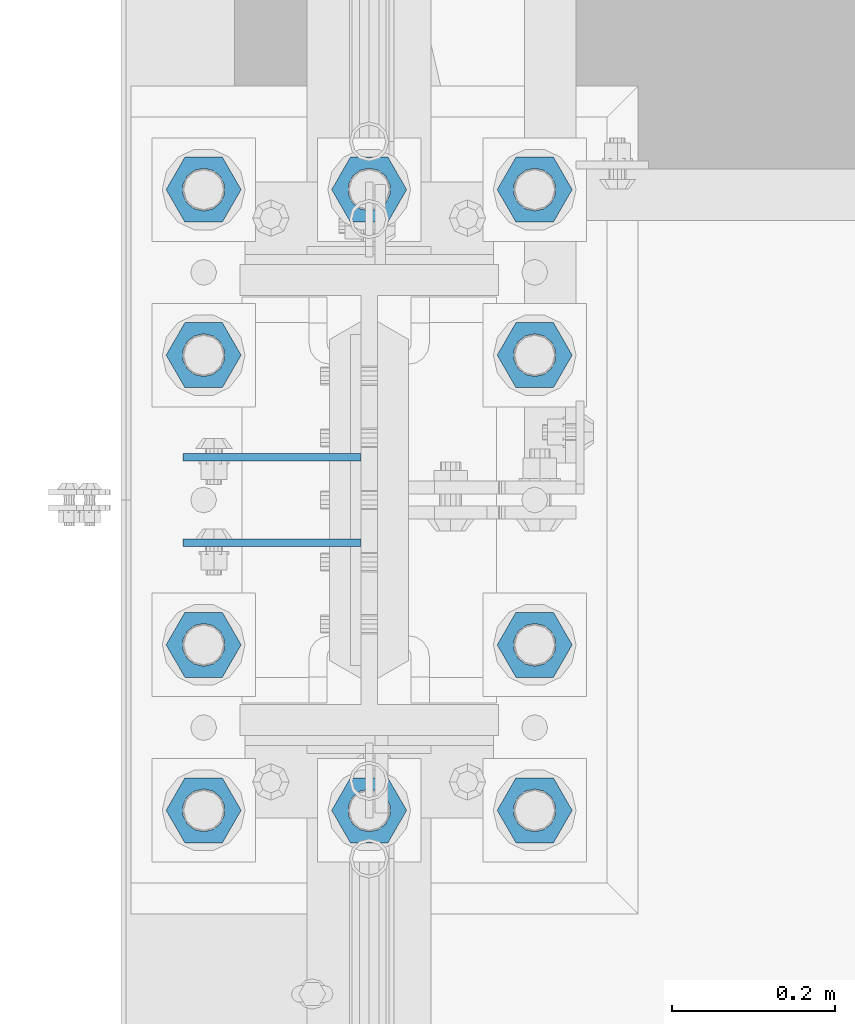
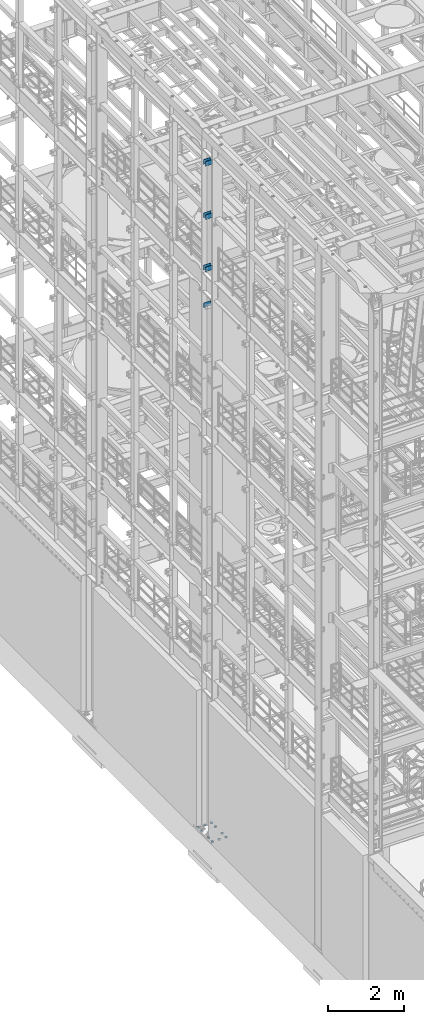
# One storey, part 1235 of 1876: 17 beams, 2 elements without a shape of their own.
"""IFC2X3 building model written with IfcOpenShell, lengths in millimetres."""

from ifc_helpers import new_model, si_unit, frame, origin_with_axes, place, context, subcontext, project, spatial, faceted_brep, material, type_object, element, aggregate, save


model = new_model("IFC2X3")

# Units and contexts
model_context = context("Model", 3, precision=1e-05, world=origin_with_axes())
body_context = subcontext(model_context, "Body", "Model", "MODEL_VIEW")
ifc_project = project(units=[si_unit("LENGTHUNIT", "METRE", prefix="MILLI"), si_unit("AREAUNIT", "SQUARE_METRE"), si_unit("VOLUMEUNIT", "CUBIC_METRE"), si_unit("MASSUNIT", "GRAM", prefix="KILO"), si_unit("TIMEUNIT", "SECOND"), si_unit("PLANEANGLEUNIT", "RADIAN"), si_unit("SOLIDANGLEUNIT", "STERADIAN"), si_unit("THERMODYNAMICTEMPERATUREUNIT", "DEGREE_CELSIUS"), si_unit("LUMINOUSINTENSITYUNIT", "LUMEN")], contexts=[model_context])

# Site, building, storey
site_placement = place(None, origin_with_axes())
site = spatial("IfcSite", under=ifc_project, at=site_placement, CompositionType="ELEMENT")
building_placement = place(site_placement, origin_with_axes())
building = spatial("IfcBuilding", under=site, at=building_placement, Name="Undefined", CompositionType="ELEMENT")
storey_placement = place(building_placement, origin_with_axes())
storey = spatial("IfcBuildingStorey", under=building, at=storey_placement, Name="Undefined", CompositionType="ELEMENT", Elevation=0.0)

# Assembly, beams
assembly_1_placement = place(storey_placement, origin_with_axes())
assembly_1 = element("IfcElementAssembly", 1, at=assembly_1_placement, inside=storey, Name="COLUMN", AssemblyPlace="NOTDEFINED", PredefinedType="RIGID_FRAME")
ifc_material_1 = material(Name="STEEL/A36")
beam_type_1 = type_object("IfcBeamType", PredefinedType="NOTDEFINED")
beam_1_placement = place(assembly_1_placement, frame((-10.31875, 1576.38750152589, 21678.9), z_axis=(0.0, 0.0, -1.0), x_axis=(-1.0, 0.0, 0.0)))
beam_1 = element("IfcBeam", 2, at=beam_1_placement, type_object=beam_type_1, material=ifc_material_1, Name="PLATE", context=body_context, shape_type="Brep", body=[
    faceted_brep([(0.0, 4.76249999999982, -76.1999999999998), (3.63797880709171e-12, 4.76249999999982, 76.1999969482422), (218.28125, 4.76250000000005, 76.2000000000007), (218.28125, 4.76250000000005, -76.2000000000007), (3.63797880709171e-12, -4.76249999999982, 76.1999969482422), (218.28125, -4.76250000000005, 76.2000000000007), (0.0, -4.76249999999982, -76.1999999999998), (218.28125, -4.76250000000005, -76.2000000000007)], [[[0, 1, 2, 3]], [[1, 4, 5, 2]], [[4, 6, 7, 5]], [[6, 0, 3, 7]], [[5, 7, 3, 2]], [[6, 4, 1, 0]]]),
])
beam_2_placement = place(assembly_1_placement, frame((-10.31875, 1471.61250152589, 21678.9), z_axis=(0.0, 0.0, -1.0), x_axis=(-1.0, 0.0, 0.0)))
beam_2 = element("IfcBeam", 3, at=beam_2_placement, type_object=beam_type_1, material=ifc_material_1, Name="PLATE", context=body_context, shape_type="Brep", body=[
    faceted_brep([(0.0, 4.76249999999982, -76.1999999999998), (3.63797880709171e-12, 4.76249999999982, 76.1999969482422), (218.28125, 4.76250000000005, 76.2000000000007), (218.28125, 4.76250000000005, -76.2000000000007), (3.63797880709171e-12, -4.76249999999982, 76.1999969482422), (218.28125, -4.76250000000005, 76.2000000000007), (0.0, -4.76249999999982, -76.1999999999998), (218.28125, -4.76250000000005, -76.2000000000007)], [[[0, 1, 2, 3]], [[1, 4, 5, 2]], [[4, 6, 7, 5]], [[6, 0, 3, 7]], [[5, 7, 3, 2]], [[6, 4, 1, 0]]]),
])
beam_3_placement = place(assembly_1_placement, frame((-10.31875, 1576.38750152589, 19958.05), z_axis=(0.0, 0.0, -1.0), x_axis=(-1.0, 0.0, 0.0)))
beam_3 = element("IfcBeam", 4, at=beam_3_placement, type_object=beam_type_1, material=ifc_material_1, Name="PLATE", context=body_context, shape_type="Brep", body=[
    faceted_brep([(0.0, 4.76249999999982, -76.1999999999998), (3.63797880709171e-12, 4.76249999999982, 76.1999969482422), (218.28125, 4.76250000000005, 76.2000000000007), (218.28125, 4.76250000000005, -76.2000000000007), (3.63797880709171e-12, -4.76249999999982, 76.1999969482422), (218.28125, -4.76250000000005, 76.2000000000007), (0.0, -4.76249999999982, -76.1999999999998), (218.28125, -4.76250000000005, -76.2000000000007)], [[[0, 1, 2, 3]], [[1, 4, 5, 2]], [[4, 6, 7, 5]], [[6, 0, 3, 7]], [[5, 7, 3, 2]], [[6, 4, 1, 0]]]),
])
beam_4_placement = place(assembly_1_placement, frame((-10.31875, 1471.61250152589, 19958.05), z_axis=(0.0, 0.0, -1.0), x_axis=(-1.0, 0.0, 0.0)))
beam_4 = element("IfcBeam", 5, at=beam_4_placement, type_object=beam_type_1, material=ifc_material_1, Name="PLATE", context=body_context, shape_type="Brep", body=[
    faceted_brep([(0.0, 4.76249999999982, -76.1999999999998), (3.63797880709171e-12, 4.76249999999982, 76.1999969482422), (218.28125, 4.76250000000005, 76.2000000000007), (218.28125, 4.76250000000005, -76.2000000000007), (3.63797880709171e-12, -4.76249999999982, 76.1999969482422), (218.28125, -4.76250000000005, 76.2000000000007), (0.0, -4.76249999999982, -76.1999999999998), (218.28125, -4.76250000000005, -76.2000000000007)], [[[0, 1, 2, 3]], [[1, 4, 5, 2]], [[4, 6, 7, 5]], [[6, 0, 3, 7]], [[5, 7, 3, 2]], [[6, 4, 1, 0]]]),
])
beam_5_placement = place(assembly_1_placement, frame((-10.31875, 1576.38750152589, 18275.3), z_axis=(0.0, 0.0, -1.0), x_axis=(-1.0, 0.0, 0.0)))
beam_5 = element("IfcBeam", 6, at=beam_5_placement, type_object=beam_type_1, material=ifc_material_1, Name="PLATE", context=body_context, shape_type="Brep", body=[
    faceted_brep([(0.0, 4.76249999999982, -76.1999999999998), (3.63797880709171e-12, 4.76249999999982, 76.1999969482422), (218.28125, 4.76250000000005, 76.2000000000007), (218.28125, 4.76250000000005, -76.2000000000007), (3.63797880709171e-12, -4.76249999999982, 76.1999969482422), (218.28125, -4.76250000000005, 76.2000000000007), (0.0, -4.76249999999982, -76.1999999999998), (218.28125, -4.76250000000005, -76.2000000000007)], [[[0, 1, 2, 3]], [[1, 4, 5, 2]], [[4, 6, 7, 5]], [[6, 0, 3, 7]], [[5, 7, 3, 2]], [[6, 4, 1, 0]]]),
])
beam_6_placement = place(assembly_1_placement, frame((-10.31875, 1471.61250152589, 18275.3), z_axis=(0.0, 0.0, -1.0), x_axis=(-1.0, 0.0, 0.0)))
beam_6 = element("IfcBeam", 7, at=beam_6_placement, type_object=beam_type_1, material=ifc_material_1, Name="PLATE", context=body_context, shape_type="Brep", body=[
    faceted_brep([(0.0, 4.76249999999982, -76.1999999999998), (3.63797880709171e-12, 4.76249999999982, 76.1999969482422), (218.28125, 4.76250000000005, 76.2000000000007), (218.28125, 4.76250000000005, -76.2000000000007), (3.63797880709171e-12, -4.76249999999982, 76.1999969482422), (218.28125, -4.76250000000005, 76.2000000000007), (0.0, -4.76249999999982, -76.1999999999998), (218.28125, -4.76250000000005, -76.2000000000007)], [[[0, 1, 2, 3]], [[1, 4, 5, 2]], [[4, 6, 7, 5]], [[6, 0, 3, 7]], [[5, 7, 3, 2]], [[6, 4, 1, 0]]]),
])
beam_7_placement = place(assembly_1_placement, frame((-10.31875, 1576.38750152589, 17056.1), z_axis=(0.0, 0.0, -1.0), x_axis=(-1.0, 0.0, 0.0)))
beam_7 = element("IfcBeam", 8, at=beam_7_placement, type_object=beam_type_1, material=ifc_material_1, Name="PLATE", context=body_context, shape_type="Brep", body=[
    faceted_brep([(0.0, 4.76249999999982, -76.1999999999998), (3.63797880709171e-12, 4.76249999999982, 76.1999969482422), (218.28125, 4.76250000000005, 76.2000000000007), (218.28125, 4.76250000000005, -76.2000000000007), (3.63797880709171e-12, -4.76249999999982, 76.1999969482422), (218.28125, -4.76250000000005, 76.2000000000007), (0.0, -4.76249999999982, -76.1999999999998), (218.28125, -4.76250000000005, -76.2000000000007)], [[[0, 1, 2, 3]], [[1, 4, 5, 2]], [[4, 6, 7, 5]], [[6, 0, 3, 7]], [[5, 7, 3, 2]], [[6, 4, 1, 0]]]),
])
aggregate(assembly_1, [beam_1, beam_2, beam_3, beam_4, beam_5, beam_6, beam_7])

assembly_2_placement = place(storey_placement, origin_with_axes())
assembly_2 = element("IfcElementAssembly", 9, at=assembly_2_placement, inside=storey, Name="TEMPLATE", AssemblyPlace="NOTDEFINED", PredefinedType="RIGID_FRAME")
ifc_material_2 = material(Name="STEEL/A563")
beam_type_2 = type_object("IfcBeamType", Name="2_DIA. HALF_NUT", PredefinedType="NOTDEFINED")
beam_8_placement = place(assembly_2_placement, frame((-203.2, 1904.99999847412, 33.3375), z_axis=(0.0, -1.0, 0.0), x_axis=(0.0, 0.0, -1.0)))
beam_8 = element("IfcBeam", 10, at=beam_8_placement, type_object=beam_type_2, material=ifc_material_2, Name="NUT", ObjectType="2_DIA. HALF_NUT", context=body_context, shape_type="Brep", body=[
    faceted_brep([(0.0, -46.0369987487793, 9.09494701772928e-13), (0.0, -23.0184993743896, -39.869213104248), (25.4, -23.0184993743896, -39.869213104248), (25.4, -46.0369987487793, 9.09494701772928e-13), (0.0, 23.0184993743896, -39.869213104248), (25.4, 23.0184993743896, -39.869213104248), (0.0, 46.0369987487793, -9.09494701772928e-13), (25.4, 46.0369987487793, -9.09494701772928e-13), (0.0, 23.0184993743896, 39.869213104248), (25.4, 23.0184993743896, 39.869213104248), (0.0, -23.0184993743896, 39.869213104248), (25.4, -23.0184993743896, 39.869213104248), (0.0, 0.0, 26.1940002441406), (0.0, 11.3650617044514, 23.5999013092769), (25.4, 11.3650617044514, 23.5999013092769), (25.4, 0.0, 26.1940002441406), (0.0, 20.4791109456437, 16.3316083006703), (25.4, 20.4791109456437, 16.3316083006703), (0.0, 25.5370200498346, 5.82867859874477), (25.4, 25.5370200498346, 5.82867859874477), (0.0, 25.5370200498346, -5.82867859874477), (25.4, 25.5370200498346, -5.82867859874477), (0.0, 20.4791109456437, -16.3316083006703), (25.4, 20.4791109456437, -16.3316083006703), (0.0, 11.3650617044514, -23.5999013092769), (25.4, 11.3650617044514, -23.5999013092769), (0.0, 0.0, -26.1940002441406), (25.4, 0.0, -26.1940002441406), (0.0, -11.3650617044514, -23.5999013092769), (25.4, -11.3650617044514, -23.5999013092769), (0.0, -20.4791109456437, -16.3316083006703), (25.4, -20.4791109456437, -16.3316083006703), (0.0, -25.5370200498346, -5.82867859874477), (25.4, -25.5370200498346, -5.82867859874477), (0.0, -25.5370200498346, 5.82867859874477), (25.4, -25.5370200498346, 5.82867859874477), (0.0, -20.4791109456437, 16.3316083006703), (25.4, -20.4791109456437, 16.3316083006703), (0.0, -11.3650617044514, 23.5999013092769), (25.4, -11.3650617044514, 23.5999013092769)], [[[0, 1, 2, 3]], [[1, 4, 5, 2]], [[4, 6, 7, 5]], [[6, 8, 9, 7]], [[8, 10, 11, 9]], [[10, 0, 3, 11]], [[12, 13, 14, 15]], [[13, 16, 17, 14]], [[16, 18, 19, 17]], [[18, 20, 21, 19]], [[20, 22, 23, 21]], [[22, 24, 25, 23]], [[24, 26, 27, 25]], [[26, 28, 29, 27]], [[28, 30, 31, 29]], [[30, 32, 33, 31]], [[32, 34, 35, 33]], [[34, 36, 37, 35]], [[36, 38, 39, 37]], [[38, 12, 15, 39]], [[5, 7, 9, 11, 3, 2], [17, 19, 21, 23, 25, 27, 29, 31, 33, 35, 37, 39, 15, 14]], [[10, 8, 6, 4, 1, 0], [38, 36, 34, 32, 30, 28, 26, 24, 22, 20, 18, 16, 13, 12]]]),
])
beam_9_placement = place(assembly_2_placement, frame((0.0, 1904.99999847412, 33.3375), z_axis=(0.0, -1.0, 0.0), x_axis=(0.0, 0.0, -1.0)))
beam_9 = element("IfcBeam", 11, at=beam_9_placement, type_object=beam_type_2, material=ifc_material_2, Name="NUT", ObjectType="2_DIA. HALF_NUT", context=body_context, shape_type="Brep", body=[
    faceted_brep([(0.0, -46.0369987487793, 9.09494701772928e-13), (0.0, -23.0184993743896, -39.869213104248), (25.4, -23.0184993743896, -39.869213104248), (25.4, -46.0369987487793, 9.09494701772928e-13), (0.0, 23.0184993743896, -39.869213104248), (25.4, 23.0184993743896, -39.869213104248), (0.0, 46.0369987487793, -9.09494701772928e-13), (25.4, 46.0369987487793, -9.09494701772928e-13), (0.0, 23.0184993743896, 39.869213104248), (25.4, 23.0184993743896, 39.869213104248), (0.0, -23.0184993743896, 39.869213104248), (25.4, -23.0184993743896, 39.869213104248), (0.0, 0.0, 26.1940002441406), (0.0, 11.3650617044514, 23.5999013092769), (25.4, 11.3650617044514, 23.5999013092769), (25.4, 0.0, 26.1940002441406), (0.0, 20.4791109456437, 16.3316083006703), (25.4, 20.4791109456437, 16.3316083006703), (0.0, 25.5370200498346, 5.82867859874477), (25.4, 25.5370200498346, 5.82867859874477), (0.0, 25.5370200498346, -5.82867859874477), (25.4, 25.5370200498346, -5.82867859874477), (0.0, 20.4791109456437, -16.3316083006703), (25.4, 20.4791109456437, -16.3316083006703), (0.0, 11.3650617044514, -23.5999013092769), (25.4, 11.3650617044514, -23.5999013092769), (0.0, 0.0, -26.1940002441406), (25.4, 0.0, -26.1940002441406), (0.0, -11.3650617044514, -23.5999013092769), (25.4, -11.3650617044514, -23.5999013092769), (0.0, -20.4791109456437, -16.3316083006703), (25.4, -20.4791109456437, -16.3316083006703), (0.0, -25.5370200498346, -5.82867859874477), (25.4, -25.5370200498346, -5.82867859874477), (0.0, -25.5370200498346, 5.82867859874477), (25.4, -25.5370200498346, 5.82867859874477), (0.0, -20.4791109456437, 16.3316083006703), (25.4, -20.4791109456437, 16.3316083006703), (0.0, -11.3650617044514, 23.5999013092769), (25.4, -11.3650617044514, 23.5999013092769)], [[[0, 1, 2, 3]], [[1, 4, 5, 2]], [[4, 6, 7, 5]], [[6, 8, 9, 7]], [[8, 10, 11, 9]], [[10, 0, 3, 11]], [[12, 13, 14, 15]], [[13, 16, 17, 14]], [[16, 18, 19, 17]], [[18, 20, 21, 19]], [[20, 22, 23, 21]], [[22, 24, 25, 23]], [[24, 26, 27, 25]], [[26, 28, 29, 27]], [[28, 30, 31, 29]], [[30, 32, 33, 31]], [[32, 34, 35, 33]], [[34, 36, 37, 35]], [[36, 38, 39, 37]], [[38, 12, 15, 39]], [[5, 7, 9, 11, 3, 2], [17, 19, 21, 23, 25, 27, 29, 31, 33, 35, 37, 39, 15, 14]], [[10, 8, 6, 4, 1, 0], [38, 36, 34, 32, 30, 28, 26, 24, 22, 20, 18, 16, 13, 12]]]),
])
beam_10_placement = place(assembly_2_placement, frame((-203.2, 1701.79999847412, 33.3375), z_axis=(0.0, -1.0, 0.0), x_axis=(0.0, 0.0, -1.0)))
beam_10 = element("IfcBeam", 12, at=beam_10_placement, type_object=beam_type_2, material=ifc_material_2, Name="NUT", ObjectType="2_DIA. HALF_NUT", context=body_context, shape_type="Brep", body=[
    faceted_brep([(0.0, -46.0369987487793, 9.09494701772928e-13), (0.0, -23.0184993743896, -39.869213104248), (25.4, -23.0184993743896, -39.869213104248), (25.4, -46.0369987487793, 9.09494701772928e-13), (0.0, 23.0184993743896, -39.869213104248), (25.4, 23.0184993743896, -39.869213104248), (0.0, 46.0369987487793, -9.09494701772928e-13), (25.4, 46.0369987487793, -9.09494701772928e-13), (0.0, 23.0184993743896, 39.869213104248), (25.4, 23.0184993743896, 39.869213104248), (0.0, -23.0184993743896, 39.869213104248), (25.4, -23.0184993743896, 39.869213104248), (0.0, 0.0, 26.1940002441406), (0.0, 11.3650617044514, 23.5999013092769), (25.4, 11.3650617044514, 23.5999013092769), (25.4, 0.0, 26.1940002441406), (0.0, 20.4791109456437, 16.3316083006703), (25.4, 20.4791109456437, 16.3316083006703), (0.0, 25.5370200498346, 5.82867859874477), (25.4, 25.5370200498346, 5.82867859874477), (0.0, 25.5370200498346, -5.82867859874477), (25.4, 25.5370200498346, -5.82867859874477), (0.0, 20.4791109456437, -16.3316083006703), (25.4, 20.4791109456437, -16.3316083006703), (0.0, 11.3650617044514, -23.5999013092769), (25.4, 11.3650617044514, -23.5999013092769), (0.0, 0.0, -26.1940002441406), (25.4, 0.0, -26.1940002441406), (0.0, -11.3650617044514, -23.5999013092769), (25.4, -11.3650617044514, -23.5999013092769), (0.0, -20.4791109456437, -16.3316083006703), (25.4, -20.4791109456437, -16.3316083006703), (0.0, -25.5370200498346, -5.82867859874477), (25.4, -25.5370200498346, -5.82867859874477), (0.0, -25.5370200498346, 5.82867859874477), (25.4, -25.5370200498346, 5.82867859874477), (0.0, -20.4791109456437, 16.3316083006703), (25.4, -20.4791109456437, 16.3316083006703), (0.0, -11.3650617044514, 23.5999013092769), (25.4, -11.3650617044514, 23.5999013092769)], [[[0, 1, 2, 3]], [[1, 4, 5, 2]], [[4, 6, 7, 5]], [[6, 8, 9, 7]], [[8, 10, 11, 9]], [[10, 0, 3, 11]], [[12, 13, 14, 15]], [[13, 16, 17, 14]], [[16, 18, 19, 17]], [[18, 20, 21, 19]], [[20, 22, 23, 21]], [[22, 24, 25, 23]], [[24, 26, 27, 25]], [[26, 28, 29, 27]], [[28, 30, 31, 29]], [[30, 32, 33, 31]], [[32, 34, 35, 33]], [[34, 36, 37, 35]], [[36, 38, 39, 37]], [[38, 12, 15, 39]], [[5, 7, 9, 11, 3, 2], [17, 19, 21, 23, 25, 27, 29, 31, 33, 35, 37, 39, 15, 14]], [[10, 8, 6, 4, 1, 0], [38, 36, 34, 32, 30, 28, 26, 24, 22, 20, 18, 16, 13, 12]]]),
])
beam_11_placement = place(assembly_2_placement, frame((203.2, 1905.00000152588, 33.3375), z_axis=(0.0, 1.0, 0.0), x_axis=(0.0, 0.0, -1.0)))
beam_11 = element("IfcBeam", 13, at=beam_11_placement, type_object=beam_type_2, material=ifc_material_2, Name="NUT", ObjectType="2_DIA. HALF_NUT", context=body_context, shape_type="Brep", body=[
    faceted_brep([(0.0, -46.0369987487793, 9.09494701772928e-13), (0.0, -23.0184993743896, -39.869213104248), (25.4, -23.0184993743896, -39.869213104248), (25.4, -46.0369987487793, 9.09494701772928e-13), (0.0, 23.0184993743896, -39.869213104248), (25.4, 23.0184993743896, -39.869213104248), (0.0, 46.0369987487793, -9.09494701772928e-13), (25.4, 46.0369987487793, -9.09494701772928e-13), (0.0, 23.0184993743896, 39.869213104248), (25.4, 23.0184993743896, 39.869213104248), (0.0, -23.0184993743896, 39.869213104248), (25.4, -23.0184993743896, 39.869213104248), (0.0, 0.0, 26.1940002441406), (0.0, 11.3650617044514, 23.5999013092769), (25.4, 11.3650617044514, 23.5999013092769), (25.4, 0.0, 26.1940002441406), (0.0, 20.4791109456437, 16.3316083006703), (25.4, 20.4791109456437, 16.3316083006703), (0.0, 25.5370200498346, 5.82867859874477), (25.4, 25.5370200498346, 5.82867859874477), (0.0, 25.5370200498346, -5.82867859874477), (25.4, 25.5370200498346, -5.82867859874477), (0.0, 20.4791109456437, -16.3316083006703), (25.4, 20.4791109456437, -16.3316083006703), (0.0, 11.3650617044514, -23.5999013092769), (25.4, 11.3650617044514, -23.5999013092769), (0.0, 0.0, -26.1940002441406), (25.4, 0.0, -26.1940002441406), (0.0, -11.3650617044514, -23.5999013092769), (25.4, -11.3650617044514, -23.5999013092769), (0.0, -20.4791109456437, -16.3316083006703), (25.4, -20.4791109456437, -16.3316083006703), (0.0, -25.5370200498346, -5.82867859874477), (25.4, -25.5370200498346, -5.82867859874477), (0.0, -25.5370200498346, 5.82867859874477), (25.4, -25.5370200498346, 5.82867859874477), (0.0, -20.4791109456437, 16.3316083006703), (25.4, -20.4791109456437, 16.3316083006703), (0.0, -11.3650617044514, 23.5999013092769), (25.4, -11.3650617044514, 23.5999013092769)], [[[0, 1, 2, 3]], [[1, 4, 5, 2]], [[4, 6, 7, 5]], [[6, 8, 9, 7]], [[8, 10, 11, 9]], [[10, 0, 3, 11]], [[12, 13, 14, 15]], [[13, 16, 17, 14]], [[16, 18, 19, 17]], [[18, 20, 21, 19]], [[20, 22, 23, 21]], [[22, 24, 25, 23]], [[24, 26, 27, 25]], [[26, 28, 29, 27]], [[28, 30, 31, 29]], [[30, 32, 33, 31]], [[32, 34, 35, 33]], [[34, 36, 37, 35]], [[36, 38, 39, 37]], [[38, 12, 15, 39]], [[5, 7, 9, 11, 3, 2], [17, 19, 21, 23, 25, 27, 29, 31, 33, 35, 37, 39, 15, 14]], [[10, 8, 6, 4, 1, 0], [38, 36, 34, 32, 30, 28, 26, 24, 22, 20, 18, 16, 13, 12]]]),
])
beam_12_placement = place(assembly_2_placement, frame((203.2, 1701.80000152588, 33.3375), z_axis=(0.0, 1.0, 0.0), x_axis=(0.0, 0.0, -1.0)))
beam_12 = element("IfcBeam", 14, at=beam_12_placement, type_object=beam_type_2, material=ifc_material_2, Name="NUT", ObjectType="2_DIA. HALF_NUT", context=body_context, shape_type="Brep", body=[
    faceted_brep([(0.0, -46.0369987487793, 9.09494701772928e-13), (0.0, -23.0184993743896, -39.869213104248), (25.4, -23.0184993743896, -39.869213104248), (25.4, -46.0369987487793, 9.09494701772928e-13), (0.0, 23.0184993743896, -39.869213104248), (25.4, 23.0184993743896, -39.869213104248), (0.0, 46.0369987487793, -9.09494701772928e-13), (25.4, 46.0369987487793, -9.09494701772928e-13), (0.0, 23.0184993743896, 39.869213104248), (25.4, 23.0184993743896, 39.869213104248), (0.0, -23.0184993743896, 39.869213104248), (25.4, -23.0184993743896, 39.869213104248), (0.0, 0.0, 26.1940002441406), (0.0, 11.3650617044514, 23.5999013092769), (25.4, 11.3650617044514, 23.5999013092769), (25.4, 0.0, 26.1940002441406), (0.0, 20.4791109456437, 16.3316083006703), (25.4, 20.4791109456437, 16.3316083006703), (0.0, 25.5370200498346, 5.82867859874477), (25.4, 25.5370200498346, 5.82867859874477), (0.0, 25.5370200498346, -5.82867859874477), (25.4, 25.5370200498346, -5.82867859874477), (0.0, 20.4791109456437, -16.3316083006703), (25.4, 20.4791109456437, -16.3316083006703), (0.0, 11.3650617044514, -23.5999013092769), (25.4, 11.3650617044514, -23.5999013092769), (0.0, 0.0, -26.1940002441406), (25.4, 0.0, -26.1940002441406), (0.0, -11.3650617044514, -23.5999013092769), (25.4, -11.3650617044514, -23.5999013092769), (0.0, -20.4791109456437, -16.3316083006703), (25.4, -20.4791109456437, -16.3316083006703), (0.0, -25.5370200498346, -5.82867859874477), (25.4, -25.5370200498346, -5.82867859874477), (0.0, -25.5370200498346, 5.82867859874477), (25.4, -25.5370200498346, 5.82867859874477), (0.0, -20.4791109456437, 16.3316083006703), (25.4, -20.4791109456437, 16.3316083006703), (0.0, -11.3650617044514, 23.5999013092769), (25.4, -11.3650617044514, 23.5999013092769)], [[[0, 1, 2, 3]], [[1, 4, 5, 2]], [[4, 6, 7, 5]], [[6, 8, 9, 7]], [[8, 10, 11, 9]], [[10, 0, 3, 11]], [[12, 13, 14, 15]], [[13, 16, 17, 14]], [[16, 18, 19, 17]], [[18, 20, 21, 19]], [[20, 22, 23, 21]], [[22, 24, 25, 23]], [[24, 26, 27, 25]], [[26, 28, 29, 27]], [[28, 30, 31, 29]], [[30, 32, 33, 31]], [[32, 34, 35, 33]], [[34, 36, 37, 35]], [[36, 38, 39, 37]], [[38, 12, 15, 39]], [[5, 7, 9, 11, 3, 2], [17, 19, 21, 23, 25, 27, 29, 31, 33, 35, 37, 39, 15, 14]], [[10, 8, 6, 4, 1, 0], [38, 36, 34, 32, 30, 28, 26, 24, 22, 20, 18, 16, 13, 12]]]),
])
beam_13_placement = place(assembly_2_placement, frame((-203.2, 1346.19999847412, 33.3375), z_axis=(0.0, -1.0, 0.0), x_axis=(0.0, 0.0, -1.0)))
beam_13 = element("IfcBeam", 15, at=beam_13_placement, type_object=beam_type_2, material=ifc_material_2, Name="NUT", ObjectType="2_DIA. HALF_NUT", context=body_context, shape_type="Brep", body=[
    faceted_brep([(0.0, -46.0369987487793, 9.09494701772928e-13), (0.0, -23.0184993743896, -39.869213104248), (25.4, -23.0184993743896, -39.869213104248), (25.4, -46.0369987487793, 9.09494701772928e-13), (0.0, 23.0184993743896, -39.869213104248), (25.4, 23.0184993743896, -39.869213104248), (0.0, 46.0369987487793, -9.09494701772928e-13), (25.4, 46.0369987487793, -9.09494701772928e-13), (0.0, 23.0184993743896, 39.869213104248), (25.4, 23.0184993743896, 39.869213104248), (0.0, -23.0184993743896, 39.869213104248), (25.4, -23.0184993743896, 39.869213104248), (0.0, 0.0, 26.1940002441406), (0.0, 11.3650617044514, 23.5999013092769), (25.4, 11.3650617044514, 23.5999013092769), (25.4, 0.0, 26.1940002441406), (0.0, 20.4791109456437, 16.3316083006703), (25.4, 20.4791109456437, 16.3316083006703), (0.0, 25.5370200498346, 5.82867859874477), (25.4, 25.5370200498346, 5.82867859874477), (0.0, 25.5370200498346, -5.82867859874477), (25.4, 25.5370200498346, -5.82867859874477), (0.0, 20.4791109456437, -16.3316083006703), (25.4, 20.4791109456437, -16.3316083006703), (0.0, 11.3650617044514, -23.5999013092769), (25.4, 11.3650617044514, -23.5999013092769), (0.0, 0.0, -26.1940002441406), (25.4, 0.0, -26.1940002441406), (0.0, -11.3650617044514, -23.5999013092769), (25.4, -11.3650617044514, -23.5999013092769), (0.0, -20.4791109456437, -16.3316083006703), (25.4, -20.4791109456437, -16.3316083006703), (0.0, -25.5370200498346, -5.82867859874477), (25.4, -25.5370200498346, -5.82867859874477), (0.0, -25.5370200498346, 5.82867859874477), (25.4, -25.5370200498346, 5.82867859874477), (0.0, -20.4791109456437, 16.3316083006703), (25.4, -20.4791109456437, 16.3316083006703), (0.0, -11.3650617044514, 23.5999013092769), (25.4, -11.3650617044514, 23.5999013092769)], [[[0, 1, 2, 3]], [[1, 4, 5, 2]], [[4, 6, 7, 5]], [[6, 8, 9, 7]], [[8, 10, 11, 9]], [[10, 0, 3, 11]], [[12, 13, 14, 15]], [[13, 16, 17, 14]], [[16, 18, 19, 17]], [[18, 20, 21, 19]], [[20, 22, 23, 21]], [[22, 24, 25, 23]], [[24, 26, 27, 25]], [[26, 28, 29, 27]], [[28, 30, 31, 29]], [[30, 32, 33, 31]], [[32, 34, 35, 33]], [[34, 36, 37, 35]], [[36, 38, 39, 37]], [[38, 12, 15, 39]], [[5, 7, 9, 11, 3, 2], [17, 19, 21, 23, 25, 27, 29, 31, 33, 35, 37, 39, 15, 14]], [[10, 8, 6, 4, 1, 0], [38, 36, 34, 32, 30, 28, 26, 24, 22, 20, 18, 16, 13, 12]]]),
])
beam_14_placement = place(assembly_2_placement, frame((203.2, 1346.20000152588, 33.3375), z_axis=(0.0, 1.0, 0.0), x_axis=(0.0, 0.0, -1.0)))
beam_14 = element("IfcBeam", 16, at=beam_14_placement, type_object=beam_type_2, material=ifc_material_2, Name="NUT", ObjectType="2_DIA. HALF_NUT", context=body_context, shape_type="Brep", body=[
    faceted_brep([(0.0, -46.0369987487793, 9.09494701772928e-13), (0.0, -23.0184993743896, -39.869213104248), (25.4, -23.0184993743896, -39.869213104248), (25.4, -46.0369987487793, 9.09494701772928e-13), (0.0, 23.0184993743896, -39.869213104248), (25.4, 23.0184993743896, -39.869213104248), (0.0, 46.0369987487793, -9.09494701772928e-13), (25.4, 46.0369987487793, -9.09494701772928e-13), (0.0, 23.0184993743896, 39.869213104248), (25.4, 23.0184993743896, 39.869213104248), (0.0, -23.0184993743896, 39.869213104248), (25.4, -23.0184993743896, 39.869213104248), (0.0, 0.0, 26.1940002441406), (0.0, 11.3650617044514, 23.5999013092769), (25.4, 11.3650617044514, 23.5999013092769), (25.4, 0.0, 26.1940002441406), (0.0, 20.4791109456437, 16.3316083006703), (25.4, 20.4791109456437, 16.3316083006703), (0.0, 25.5370200498346, 5.82867859874477), (25.4, 25.5370200498346, 5.82867859874477), (0.0, 25.5370200498346, -5.82867859874477), (25.4, 25.5370200498346, -5.82867859874477), (0.0, 20.4791109456437, -16.3316083006703), (25.4, 20.4791109456437, -16.3316083006703), (0.0, 11.3650617044514, -23.5999013092769), (25.4, 11.3650617044514, -23.5999013092769), (0.0, 0.0, -26.1940002441406), (25.4, 0.0, -26.1940002441406), (0.0, -11.3650617044514, -23.5999013092769), (25.4, -11.3650617044514, -23.5999013092769), (0.0, -20.4791109456437, -16.3316083006703), (25.4, -20.4791109456437, -16.3316083006703), (0.0, -25.5370200498346, -5.82867859874477), (25.4, -25.5370200498346, -5.82867859874477), (0.0, -25.5370200498346, 5.82867859874477), (25.4, -25.5370200498346, 5.82867859874477), (0.0, -20.4791109456437, 16.3316083006703), (25.4, -20.4791109456437, 16.3316083006703), (0.0, -11.3650617044514, 23.5999013092769), (25.4, -11.3650617044514, 23.5999013092769)], [[[0, 1, 2, 3]], [[1, 4, 5, 2]], [[4, 6, 7, 5]], [[6, 8, 9, 7]], [[8, 10, 11, 9]], [[10, 0, 3, 11]], [[12, 13, 14, 15]], [[13, 16, 17, 14]], [[16, 18, 19, 17]], [[18, 20, 21, 19]], [[20, 22, 23, 21]], [[22, 24, 25, 23]], [[24, 26, 27, 25]], [[26, 28, 29, 27]], [[28, 30, 31, 29]], [[30, 32, 33, 31]], [[32, 34, 35, 33]], [[34, 36, 37, 35]], [[36, 38, 39, 37]], [[38, 12, 15, 39]], [[5, 7, 9, 11, 3, 2], [17, 19, 21, 23, 25, 27, 29, 31, 33, 35, 37, 39, 15, 14]], [[10, 8, 6, 4, 1, 0], [38, 36, 34, 32, 30, 28, 26, 24, 22, 20, 18, 16, 13, 12]]]),
])
beam_15_placement = place(assembly_2_placement, frame((203.2, 1143.00000152588, 33.3375), z_axis=(0.0, 1.0, 0.0), x_axis=(0.0, 0.0, -1.0)))
beam_15 = element("IfcBeam", 17, at=beam_15_placement, type_object=beam_type_2, material=ifc_material_2, Name="NUT", ObjectType="2_DIA. HALF_NUT", context=body_context, shape_type="Brep", body=[
    faceted_brep([(0.0, -46.0369987487793, 9.09494701772928e-13), (0.0, -23.0184993743896, -39.869213104248), (25.4, -23.0184993743896, -39.869213104248), (25.4, -46.0369987487793, 9.09494701772928e-13), (0.0, 23.0184993743896, -39.869213104248), (25.4, 23.0184993743896, -39.869213104248), (0.0, 46.0369987487793, -9.09494701772928e-13), (25.4, 46.0369987487793, -9.09494701772928e-13), (0.0, 23.0184993743896, 39.869213104248), (25.4, 23.0184993743896, 39.869213104248), (0.0, -23.0184993743896, 39.869213104248), (25.4, -23.0184993743896, 39.869213104248), (0.0, 0.0, 26.1940002441406), (0.0, 11.3650617044514, 23.5999013092769), (25.4, 11.3650617044514, 23.5999013092769), (25.4, 0.0, 26.1940002441406), (0.0, 20.4791109456437, 16.3316083006703), (25.4, 20.4791109456437, 16.3316083006703), (0.0, 25.5370200498346, 5.82867859874477), (25.4, 25.5370200498346, 5.82867859874477), (0.0, 25.5370200498346, -5.82867859874477), (25.4, 25.5370200498346, -5.82867859874477), (0.0, 20.4791109456437, -16.3316083006703), (25.4, 20.4791109456437, -16.3316083006703), (0.0, 11.3650617044514, -23.5999013092769), (25.4, 11.3650617044514, -23.5999013092769), (0.0, 0.0, -26.1940002441406), (25.4, 0.0, -26.1940002441406), (0.0, -11.3650617044514, -23.5999013092769), (25.4, -11.3650617044514, -23.5999013092769), (0.0, -20.4791109456437, -16.3316083006703), (25.4, -20.4791109456437, -16.3316083006703), (0.0, -25.5370200498346, -5.82867859874477), (25.4, -25.5370200498346, -5.82867859874477), (0.0, -25.5370200498346, 5.82867859874477), (25.4, -25.5370200498346, 5.82867859874477), (0.0, -20.4791109456437, 16.3316083006703), (25.4, -20.4791109456437, 16.3316083006703), (0.0, -11.3650617044514, 23.5999013092769), (25.4, -11.3650617044514, 23.5999013092769)], [[[0, 1, 2, 3]], [[1, 4, 5, 2]], [[4, 6, 7, 5]], [[6, 8, 9, 7]], [[8, 10, 11, 9]], [[10, 0, 3, 11]], [[12, 13, 14, 15]], [[13, 16, 17, 14]], [[16, 18, 19, 17]], [[18, 20, 21, 19]], [[20, 22, 23, 21]], [[22, 24, 25, 23]], [[24, 26, 27, 25]], [[26, 28, 29, 27]], [[28, 30, 31, 29]], [[30, 32, 33, 31]], [[32, 34, 35, 33]], [[34, 36, 37, 35]], [[36, 38, 39, 37]], [[38, 12, 15, 39]], [[5, 7, 9, 11, 3, 2], [17, 19, 21, 23, 25, 27, 29, 31, 33, 35, 37, 39, 15, 14]], [[10, 8, 6, 4, 1, 0], [38, 36, 34, 32, 30, 28, 26, 24, 22, 20, 18, 16, 13, 12]]]),
])
beam_16_placement = place(assembly_2_placement, frame((0.0, 1142.99999847412, 33.3375), z_axis=(0.0, -1.0, 0.0), x_axis=(0.0, 0.0, -1.0)))
beam_16 = element("IfcBeam", 18, at=beam_16_placement, type_object=beam_type_2, material=ifc_material_2, Name="NUT", ObjectType="2_DIA. HALF_NUT", context=body_context, shape_type="Brep", body=[
    faceted_brep([(0.0, -46.0369987487793, 9.09494701772928e-13), (0.0, -23.0184993743896, -39.869213104248), (25.4, -23.0184993743896, -39.869213104248), (25.4, -46.0369987487793, 9.09494701772928e-13), (0.0, 23.0184993743896, -39.869213104248), (25.4, 23.0184993743896, -39.869213104248), (0.0, 46.0369987487793, -9.09494701772928e-13), (25.4, 46.0369987487793, -9.09494701772928e-13), (0.0, 23.0184993743896, 39.869213104248), (25.4, 23.0184993743896, 39.869213104248), (0.0, -23.0184993743896, 39.869213104248), (25.4, -23.0184993743896, 39.869213104248), (0.0, 0.0, 26.1940002441406), (0.0, 11.3650617044514, 23.5999013092769), (25.4, 11.3650617044514, 23.5999013092769), (25.4, 0.0, 26.1940002441406), (0.0, 20.4791109456437, 16.3316083006703), (25.4, 20.4791109456437, 16.3316083006703), (0.0, 25.5370200498346, 5.82867859874477), (25.4, 25.5370200498346, 5.82867859874477), (0.0, 25.5370200498346, -5.82867859874477), (25.4, 25.5370200498346, -5.82867859874477), (0.0, 20.4791109456437, -16.3316083006703), (25.4, 20.4791109456437, -16.3316083006703), (0.0, 11.3650617044514, -23.5999013092769), (25.4, 11.3650617044514, -23.5999013092769), (0.0, 0.0, -26.1940002441406), (25.4, 0.0, -26.1940002441406), (0.0, -11.3650617044514, -23.5999013092769), (25.4, -11.3650617044514, -23.5999013092769), (0.0, -20.4791109456437, -16.3316083006703), (25.4, -20.4791109456437, -16.3316083006703), (0.0, -25.5370200498346, -5.82867859874477), (25.4, -25.5370200498346, -5.82867859874477), (0.0, -25.5370200498346, 5.82867859874477), (25.4, -25.5370200498346, 5.82867859874477), (0.0, -20.4791109456437, 16.3316083006703), (25.4, -20.4791109456437, 16.3316083006703), (0.0, -11.3650617044514, 23.5999013092769), (25.4, -11.3650617044514, 23.5999013092769)], [[[0, 1, 2, 3]], [[1, 4, 5, 2]], [[4, 6, 7, 5]], [[6, 8, 9, 7]], [[8, 10, 11, 9]], [[10, 0, 3, 11]], [[12, 13, 14, 15]], [[13, 16, 17, 14]], [[16, 18, 19, 17]], [[18, 20, 21, 19]], [[20, 22, 23, 21]], [[22, 24, 25, 23]], [[24, 26, 27, 25]], [[26, 28, 29, 27]], [[28, 30, 31, 29]], [[30, 32, 33, 31]], [[32, 34, 35, 33]], [[34, 36, 37, 35]], [[36, 38, 39, 37]], [[38, 12, 15, 39]], [[5, 7, 9, 11, 3, 2], [17, 19, 21, 23, 25, 27, 29, 31, 33, 35, 37, 39, 15, 14]], [[10, 8, 6, 4, 1, 0], [38, 36, 34, 32, 30, 28, 26, 24, 22, 20, 18, 16, 13, 12]]]),
])
beam_17_placement = place(assembly_2_placement, frame((-203.2, 1142.99999847412, 33.3375), z_axis=(0.0, -1.0, 0.0), x_axis=(0.0, 0.0, -1.0)))
beam_17 = element("IfcBeam", 19, at=beam_17_placement, type_object=beam_type_2, material=ifc_material_2, Name="NUT", ObjectType="2_DIA. HALF_NUT", context=body_context, shape_type="Brep", body=[
    faceted_brep([(0.0, -46.0369987487793, 9.09494701772928e-13), (0.0, -23.0184993743896, -39.869213104248), (25.4, -23.0184993743896, -39.869213104248), (25.4, -46.0369987487793, 9.09494701772928e-13), (0.0, 23.0184993743896, -39.869213104248), (25.4, 23.0184993743896, -39.869213104248), (0.0, 46.0369987487793, -9.09494701772928e-13), (25.4, 46.0369987487793, -9.09494701772928e-13), (0.0, 23.0184993743896, 39.869213104248), (25.4, 23.0184993743896, 39.869213104248), (0.0, -23.0184993743896, 39.869213104248), (25.4, -23.0184993743896, 39.869213104248), (0.0, 0.0, 26.1940002441406), (0.0, 11.3650617044514, 23.5999013092769), (25.4, 11.3650617044514, 23.5999013092769), (25.4, 0.0, 26.1940002441406), (0.0, 20.4791109456437, 16.3316083006703), (25.4, 20.4791109456437, 16.3316083006703), (0.0, 25.5370200498346, 5.82867859874477), (25.4, 25.5370200498346, 5.82867859874477), (0.0, 25.5370200498346, -5.82867859874477), (25.4, 25.5370200498346, -5.82867859874477), (0.0, 20.4791109456437, -16.3316083006703), (25.4, 20.4791109456437, -16.3316083006703), (0.0, 11.3650617044514, -23.5999013092769), (25.4, 11.3650617044514, -23.5999013092769), (0.0, 0.0, -26.1940002441406), (25.4, 0.0, -26.1940002441406), (0.0, -11.3650617044514, -23.5999013092769), (25.4, -11.3650617044514, -23.5999013092769), (0.0, -20.4791109456437, -16.3316083006703), (25.4, -20.4791109456437, -16.3316083006703), (0.0, -25.5370200498346, -5.82867859874477), (25.4, -25.5370200498346, -5.82867859874477), (0.0, -25.5370200498346, 5.82867859874477), (25.4, -25.5370200498346, 5.82867859874477), (0.0, -20.4791109456437, 16.3316083006703), (25.4, -20.4791109456437, 16.3316083006703), (0.0, -11.3650617044514, 23.5999013092769), (25.4, -11.3650617044514, 23.5999013092769)], [[[0, 1, 2, 3]], [[1, 4, 5, 2]], [[4, 6, 7, 5]], [[6, 8, 9, 7]], [[8, 10, 11, 9]], [[10, 0, 3, 11]], [[12, 13, 14, 15]], [[13, 16, 17, 14]], [[16, 18, 19, 17]], [[18, 20, 21, 19]], [[20, 22, 23, 21]], [[22, 24, 25, 23]], [[24, 26, 27, 25]], [[26, 28, 29, 27]], [[28, 30, 31, 29]], [[30, 32, 33, 31]], [[32, 34, 35, 33]], [[34, 36, 37, 35]], [[36, 38, 39, 37]], [[38, 12, 15, 39]], [[5, 7, 9, 11, 3, 2], [17, 19, 21, 23, 25, 27, 29, 31, 33, 35, 37, 39, 15, 14]], [[10, 8, 6, 4, 1, 0], [38, 36, 34, 32, 30, 28, 26, 24, 22, 20, 18, 16, 13, 12]]]),
])
aggregate(assembly_2, [beam_8, beam_9, beam_10, beam_11, beam_12, beam_13, beam_14, beam_15, beam_16, beam_17])

save(model, "model.ifc")
